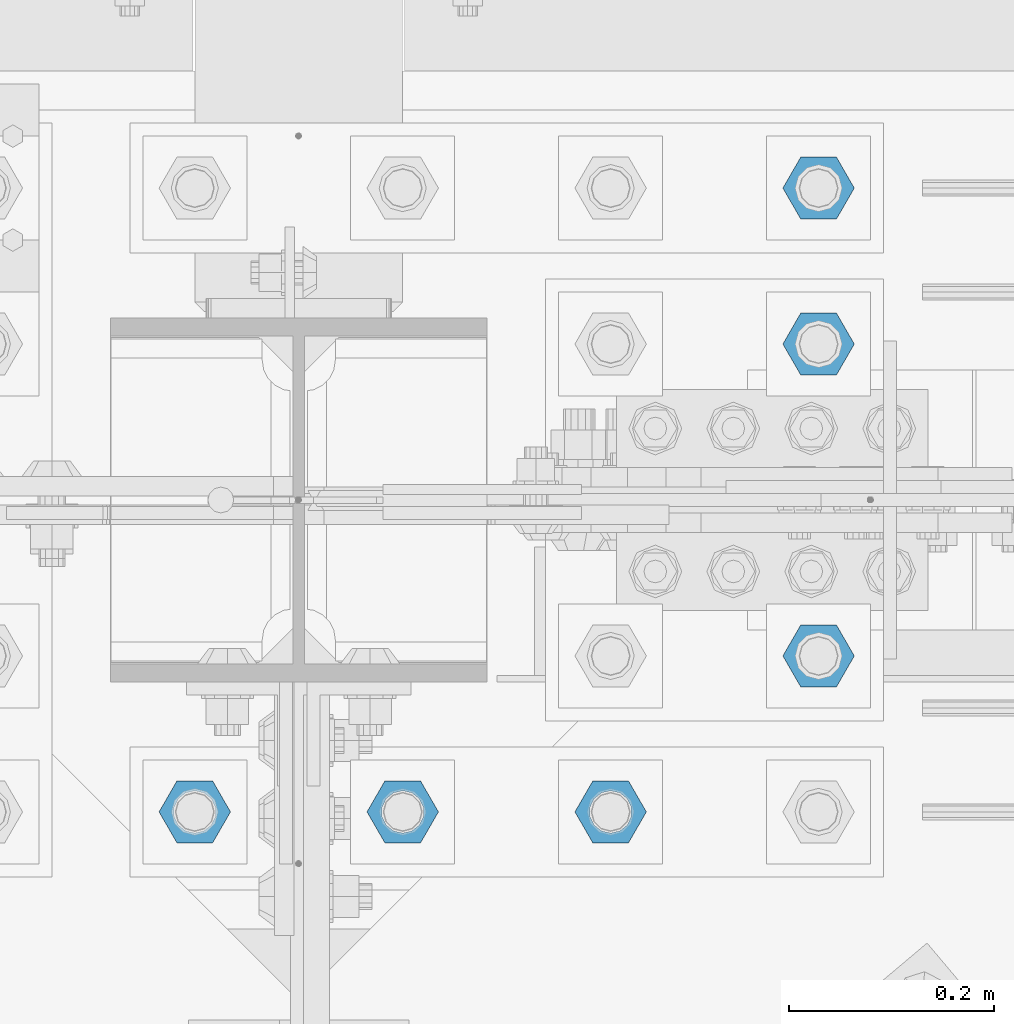
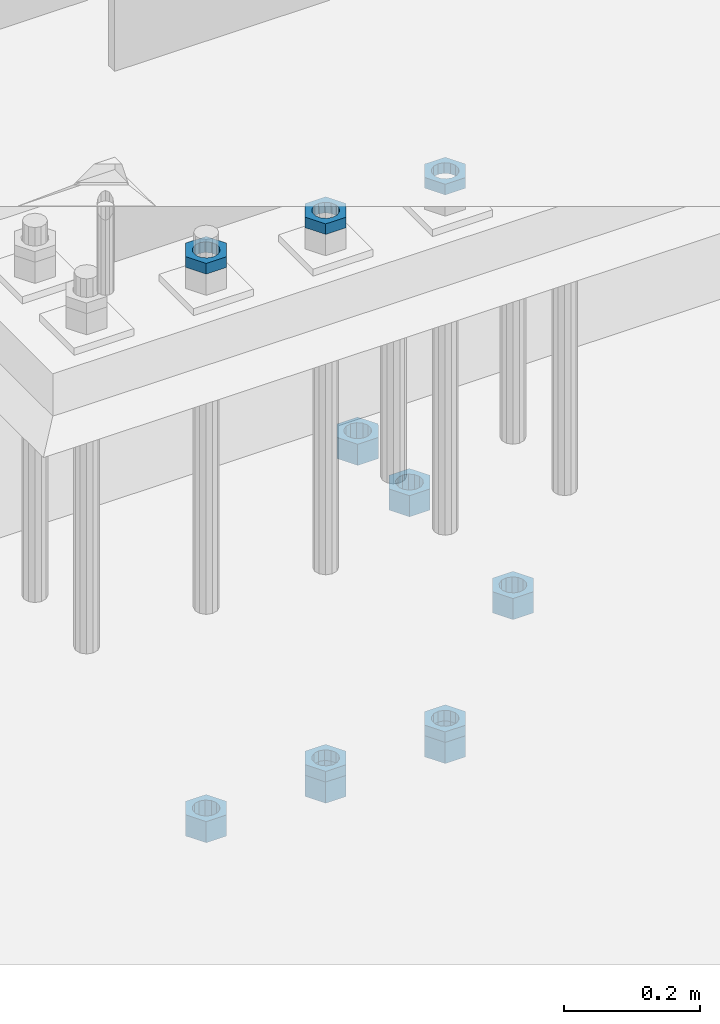
# One storey, part 2881 of 3843: 11 beams, 1 element without a shape of its own.
"""IFC2X3 building model written with IfcOpenShell, lengths in millimetres."""

import ifcopenshell
import ifcopenshell.guid

model = None  # the IFC model being written
_history = None  # IfcOwnerHistory: only IFC2X3 demands one
_inside = {}  # id of a spatial element -> (the spatial element, [elements in it])
_under = {}  # id of a project, library or spatial element -> (it, [spatial elements below it])
_declared = {}  # id of a project -> (the project, [libraries it declares])
_typed = {}  # id of a type object -> (the type object, [elements of that type])
_made_of = {}  # id of a material, layer set ... -> (it, [elements and type objects made of it])


def new_model(schema):
    """Start an empty IFC model of exactly this schema.

    Asked for "IFC4X3", IfcOpenShell would pick the latest addendum, in which some entities
    have other attributes; the version numbers below select the first issue.
    IFC2X3 requires an IfcOwnerHistory on every rooted entity: one is made here for all.
    """
    global model, _history
    if schema == "IFC4X3":
        model = ifcopenshell.file(schema_version=(4, 3, 0, 0))
    else:
        model = ifcopenshell.file(schema=schema)
    _inside.clear()
    _under.clear()
    _declared.clear()
    _typed.clear()
    _made_of.clear()
    _history = None
    if model.schema == "IFC2X3":
        org = make("IfcOrganization", Name="unknown")
        user = make(
            "IfcPersonAndOrganization",
            ThePerson=make("IfcPerson", FamilyName="unknown"),
            TheOrganization=org,
        )
        app = make(
            "IfcApplication",
            ApplicationDeveloper=org,
            Version="unknown",
            ApplicationFullName="unknown",
            ApplicationIdentifier="unknown",
        )
        _history = make(
            "IfcOwnerHistory",
            OwningUser=user,
            OwningApplication=app,
            ChangeAction="ADDED",
            CreationDate=0,
        )
    return model


def make(cls, **values):
    """One entity of the class cls with the attributes given. An attribute that is None is left unset."""
    return model.create_entity(
        cls, **{name: value for name, value in values.items() if value is not None}
    )


def rooted(cls, **values):
    """An entity with a GlobalId (a new one), such as an element, a storey or a relation."""
    return make(cls, GlobalId=ifcopenshell.guid.new(), OwnerHistory=_history, **values)


def si_unit(unit_type, name, prefix=None):
    """IfcSIUnit, for example si_unit("LENGTHUNIT", "METRE", prefix="MILLI")."""
    return make("IfcSIUnit", UnitType=unit_type, Prefix=prefix, Name=name)


def assignment(units):
    """IfcUnitAssignment: the units of a project."""
    return None if units is None else make("IfcUnitAssignment", Units=units)


def point(xyz):
    """IfcCartesianPoint."""
    return None if xyz is None else make("IfcCartesianPoint", Coordinates=xyz)


def direction(xyz):
    """IfcDirection."""
    return None if xyz is None else make("IfcDirection", DirectionRatios=xyz)


def frame(location, z_axis=None, x_axis=None):
    """IfcAxis2Placement3D, a coordinate frame: its origin and axes. An axis left out is left unset."""
    return make(
        "IfcAxis2Placement3D",
        Location=point(location),
        Axis=direction(z_axis),
        RefDirection=direction(x_axis),
    )


def origin_with_axes():
    """The frame at (0, 0, 0) with the z axis (0, 0, 1) and the x axis (1, 0, 0) written out."""
    return frame((0.0, 0.0, 0.0), z_axis=(0.0, 0.0, 1.0), x_axis=(1.0, 0.0, 0.0))


def place(relative_to, where):
    """IfcLocalPlacement: puts the frame where relative to a parent placement (None: the world)."""
    return make(
        "IfcLocalPlacement", PlacementRelTo=relative_to, RelativePlacement=where
    )


def context(
    kind, dimensions, precision=None, world=None, true_north=None, identifier=None
):
    """IfcGeometricRepresentationContext, for example the 3D "Model" context."""
    return make(
        "IfcGeometricRepresentationContext",
        ContextIdentifier=identifier,
        ContextType=kind,
        CoordinateSpaceDimension=dimensions,
        Precision=precision,
        WorldCoordinateSystem=world,
        TrueNorth=true_north,
    )


def subcontext(parent, identifier, kind, view, scale=None):
    """IfcGeometricRepresentationSubContext, for example "Body" below "Model"."""
    return make(
        "IfcGeometricRepresentationSubContext",
        ContextIdentifier=identifier,
        ContextType=kind,
        ParentContext=parent,
        TargetScale=scale,
        TargetView=view,
    )


def project(units=None, contexts=None):
    """IfcProject with its units and contexts."""
    return rooted(
        "IfcProject",
        Name="project",
        RepresentationContexts=contexts,
        UnitsInContext=assignment(units),
    )


def spatial(cls, under=None, at=None, **own):
    """A site, building, storey or space (cls), placed at a placement, below another one or the project."""
    s = rooted(cls, ObjectPlacement=at, **own)
    if under is not None:
        _under.setdefault(under.id(), (under, []))[1].append(s)
    return s


def faces_of(points, faces, orient=None, outer=None):
    """IfcFace entities. A face is a list of loops; a loop is a list of indices into points, from 0.

    orient and outer hold one flag for each loop. By default every Orientation is true, the
    first loop of a face is its IfcFaceOuterBound and the others are IfcFaceBound.
    """
    made = []
    for i, loops in enumerate(faces):
        bounds = []
        for j, loop in enumerate(loops):
            is_outer = j == 0 if outer is None else outer[i][j]
            bounds.append(
                make(
                    "IfcFaceOuterBound" if is_outer else "IfcFaceBound",
                    Bound=make("IfcPolyLoop", Polygon=[points[k] for k in loop]),
                    Orientation=True if orient is None else orient[i][j],
                )
            )
        made.append(make("IfcFace", Bounds=bounds))
    return made


def faceted_brep(points, faces, orient=None, outer=None, voids=None):
    """IfcFacetedBrep: a solid bounded by flat faces; with voids (closed shells), ...WithVoids."""
    shared = [point(p) for p in points]
    hull = make("IfcClosedShell", CfsFaces=faces_of(shared, faces, orient, outer))
    if voids is None:
        return make("IfcFacetedBrep", Outer=hull)
    return make(
        "IfcFacetedBrepWithVoids",
        Outer=hull,
        Voids=[
            make(cls, CfsFaces=faces_of(shared, fs, o, b)) for cls, fs, o, b in voids
        ],
    )


def shape(context_of_items, identifier, shape_type, items):
    """IfcShapeRepresentation: the items that make up one representation, for example the "Body"."""
    return make(
        "IfcShapeRepresentation",
        ContextOfItems=context_of_items,
        RepresentationIdentifier=identifier,
        RepresentationType=shape_type,
        Items=items,
    )


def material(Name=None, Category=None):
    """IfcMaterial."""
    return make("IfcMaterial", Name=Name, Category=Category)


def made_of(thing, what):
    """Note that an element or type object is made of a material, layer set ...; save() writes the relation."""
    if what is not None:
        _made_of.setdefault(what.id(), (what, []))[1].append(thing)
    return thing


def type_object(cls, material=None, **own):
    """A type object (cls), such as IfcWallType, which elements share."""
    return made_of(rooted(cls, **own), material)


def element(
    cls,
    number,
    at=None,
    inside=None,
    cuts=None,
    type_object=None,
    material=None,
    context=None,
    identifier="Body",
    shape_type=None,
    held_by="IfcProductDefinitionShape",
    body=None,
    shapes=None,
    **own,
):
    """One element of the class cls, such as IfcWall. Its Tag is "e" and its number.

    at: its placement. inside: the storey or other place that contains it. cuts: it is an
    opening in that element (IfcRelVoidsElement). A single representation is given by context,
    identifier, shape_type and body (its items); several are given by shapes. held_by: the class
    of the entity that holds the representations. save() writes the other relations.
    """
    e = rooted(cls, Tag="e%d" % number, ObjectPlacement=at, **own)
    if body is not None:
        shapes = [shape(context, identifier, shape_type, body)]
    if shapes is not None:
        e.Representation = make(held_by, Representations=shapes)
    if inside is not None:
        _inside.setdefault(inside.id(), (inside, []))[1].append(e)
    if cuts is not None:
        rooted(
            "IfcRelVoidsElement", RelatingBuildingElement=cuts, RelatedOpeningElement=e
        )
    if type_object is not None:
        _typed.setdefault(type_object.id(), (type_object, []))[1].append(e)
    return made_of(e, material)


def aggregate(whole, parts):
    """IfcRelAggregates: a whole, such as a stair, and the parts it consists of."""
    return rooted("IfcRelAggregates", RelatingObject=whole, RelatedObjects=parts)


def save(model, path):
    """Write the relations noted so far, then the file.

    IfcRelAggregates (storeys below a building ...), IfcRelContainedInSpatialStructure (elements
    in a storey), IfcRelDefinesByType, IfcRelAssociatesMaterial and IfcRelDeclares: one each for
    every whole, place, type object, material and project.
    """
    for whole, parts in _under.values():
        aggregate(whole, parts)
    for where, things in _inside.values():
        rooted(
            "IfcRelContainedInSpatialStructure",
            RelatedElements=things,
            RelatingStructure=where,
        )
    for kind, things in _typed.values():
        rooted("IfcRelDefinesByType", RelatedObjects=things, RelatingType=kind)
    for what, things in _made_of.values():
        rooted("IfcRelAssociatesMaterial", RelatedObjects=things, RelatingMaterial=what)
    for by, libraries in _declared.values():
        rooted("IfcRelDeclares", RelatingContext=by, RelatedDefinitions=libraries)
    model.write(path)


model = new_model("IFC2X3")

# Units and contexts
model_context = context("Model", 3, precision=1e-05, world=origin_with_axes())
body_context = subcontext(model_context, "Body", "Model", "MODEL_VIEW")
ifc_project = project(units=[si_unit("LENGTHUNIT", "METRE", prefix="MILLI"), si_unit("AREAUNIT", "SQUARE_METRE"), si_unit("VOLUMEUNIT", "CUBIC_METRE"), si_unit("MASSUNIT", "GRAM", prefix="KILO"), si_unit("TIMEUNIT", "SECOND"), si_unit("PLANEANGLEUNIT", "RADIAN"), si_unit("SOLIDANGLEUNIT", "STERADIAN"), si_unit("THERMODYNAMICTEMPERATUREUNIT", "DEGREE_CELSIUS"), si_unit("LUMINOUSINTENSITYUNIT", "LUMEN")], contexts=[model_context])

# Site, building, storey
site_placement = place(None, origin_with_axes())
site = spatial("IfcSite", under=ifc_project, at=site_placement, CompositionType="ELEMENT")
building_placement = place(site_placement, origin_with_axes())
building = spatial("IfcBuilding", under=site, at=building_placement, Name="Undefined", CompositionType="ELEMENT")
storey_placement = place(building_placement, origin_with_axes())
storey = spatial("IfcBuildingStorey", under=building, at=storey_placement, Name="Undefined", CompositionType="ELEMENT", Elevation=0.0)

# Assembly, beams
assembly_placement = place(storey_placement, origin_with_axes())
assembly = element("IfcElementAssembly", 1, at=assembly_placement, inside=storey, Name="TEMPLATE", AssemblyPlace="NOTDEFINED", PredefinedType="RIGID_FRAME")
ifc_material = material(Name="STEEL/A572-50")
beam_type_1 = type_object("IfcBeamType", Name="1-1/2_HEAVY_HEX_NUT", PredefinedType="NOTDEFINED")
beam_1_placement = place(assembly_placement, frame((49504.6, 92519.5, 29298.9000015259), z_axis=(0.0, 1.0, 0.0), x_axis=(0.0, 0.0, -1.0)))
beam_1 = element("IfcBeam", 2, at=beam_1_placement, type_object=beam_type_1, material=ifc_material, Name="NUT", ObjectType="1-1/2_HEAVY_HEX_NUT", context=body_context, shape_type="Brep", body=[
    faceted_brep([(0.0, -34.9199981689453, 0.0), (0.0, -17.4599990844727, -30.25), (38.0999999999985, -17.4599990844727, -30.25), (38.0999999999985, -34.9199981689453, 0.0), (0.0, 17.4599990844727, -30.25), (38.0999999999985, 17.4599990844727, -30.25), (0.0, 34.9199981689453, 0.0), (38.0999999999985, 34.9199981689453, 0.0), (0.0, 17.4599990844727, 30.25), (38.0999999999985, 17.4599990844727, 30.25), (0.0, -17.4599990844727, 30.25), (38.0999999999985, -17.4599990844727, 30.25), (0.0, 0.0, 20.6399993896484), (0.0, 8.9553601105581, 18.5959968835959), (38.0999999999985, 8.9553601105581, 18.5959968835959), (38.0999999999985, 0.0, 20.6399993896484), (0.0, 16.1370013209525, 12.8688291298167), (38.0999999999985, 16.1370013209525, 12.8688291298167), (0.0, 20.1225115123816, 4.59283194104501), (38.0999999999985, 20.1225115123816, 4.59283194104501), (0.0, 20.1225115123816, -4.59283194104501), (38.0999999999985, 20.1225115123816, -4.59283194104501), (0.0, 16.1370013209525, -12.8688291298167), (38.0999999999985, 16.1370013209525, -12.8688291298167), (0.0, 8.9553601105581, -18.5959968835959), (38.0999999999985, 8.9553601105581, -18.5959968835959), (0.0, 0.0, -20.6399993896484), (38.0999999999985, 0.0, -20.6399993896484), (0.0, -8.9553601105581, -18.5959968835959), (38.0999999999985, -8.9553601105581, -18.5959968835959), (0.0, -16.1370013209525, -12.8688291298167), (38.0999999999985, -16.1370013209525, -12.8688291298167), (0.0, -20.1225115123816, -4.59283194104501), (38.0999999999985, -20.1225115123816, -4.59283194104501), (0.0, -20.1225115123816, 4.59283194104501), (38.0999999999985, -20.1225115123816, 4.59283194104501), (0.0, -16.1370013209525, 12.8688291298167), (38.0999999999985, -16.1370013209525, 12.8688291298167), (0.0, -8.9553601105581, 18.5959968835959), (38.0999999999985, -8.9553601105581, 18.5959968835959)], [[[0, 1, 2, 3]], [[1, 4, 5, 2]], [[4, 6, 7, 5]], [[6, 8, 9, 7]], [[8, 10, 11, 9]], [[10, 0, 3, 11]], [[12, 13, 14, 15]], [[13, 16, 17, 14]], [[16, 18, 19, 17]], [[18, 20, 21, 19]], [[20, 22, 23, 21]], [[22, 24, 25, 23]], [[24, 26, 27, 25]], [[26, 28, 29, 27]], [[28, 30, 31, 29]], [[30, 32, 33, 31]], [[32, 34, 35, 33]], [[34, 36, 37, 35]], [[36, 38, 39, 37]], [[38, 12, 15, 39]], [[5, 7, 9, 11, 3, 2], [17, 19, 21, 23, 25, 27, 29, 31, 33, 35, 37, 39, 15, 14]], [[10, 8, 6, 4, 1, 0], [38, 36, 34, 32, 30, 28, 26, 24, 22, 20, 18, 16, 13, 12]]]),
])
beam_2_placement = place(assembly_placement, frame((49504.6, 92367.1, 29298.9000015259), z_axis=(0.0, 1.0, 0.0), x_axis=(0.0, 0.0, -1.0)))
beam_2 = element("IfcBeam", 3, at=beam_2_placement, type_object=beam_type_1, material=ifc_material, Name="NUT", ObjectType="1-1/2_HEAVY_HEX_NUT", context=body_context, shape_type="Brep", body=[
    faceted_brep([(0.0, -34.9199981689453, 0.0), (0.0, -17.4599990844727, -30.25), (38.0999999999985, -17.4599990844727, -30.25), (38.0999999999985, -34.9199981689453, 0.0), (0.0, 17.4599990844727, -30.25), (38.0999999999985, 17.4599990844727, -30.25), (0.0, 34.9199981689453, 0.0), (38.0999999999985, 34.9199981689453, 0.0), (0.0, 17.4599990844727, 30.25), (38.0999999999985, 17.4599990844727, 30.25), (0.0, -17.4599990844727, 30.25), (38.0999999999985, -17.4599990844727, 30.25), (0.0, 0.0, 20.6399993896484), (0.0, 8.9553601105581, 18.5959968835959), (38.0999999999985, 8.9553601105581, 18.5959968835959), (38.0999999999985, 0.0, 20.6399993896484), (0.0, 16.1370013209525, 12.8688291298167), (38.0999999999985, 16.1370013209525, 12.8688291298167), (0.0, 20.1225115123816, 4.59283194104501), (38.0999999999985, 20.1225115123816, 4.59283194104501), (0.0, 20.1225115123816, -4.59283194104501), (38.0999999999985, 20.1225115123816, -4.59283194104501), (0.0, 16.1370013209525, -12.8688291298167), (38.0999999999985, 16.1370013209525, -12.8688291298167), (0.0, 8.9553601105581, -18.5959968835959), (38.0999999999985, 8.9553601105581, -18.5959968835959), (0.0, 0.0, -20.6399993896484), (38.0999999999985, 0.0, -20.6399993896484), (0.0, -8.9553601105581, -18.5959968835959), (38.0999999999985, -8.9553601105581, -18.5959968835959), (0.0, -16.1370013209525, -12.8688291298167), (38.0999999999985, -16.1370013209525, -12.8688291298167), (0.0, -20.1225115123816, -4.59283194104501), (38.0999999999985, -20.1225115123816, -4.59283194104501), (0.0, -20.1225115123816, 4.59283194104501), (38.0999999999985, -20.1225115123816, 4.59283194104501), (0.0, -16.1370013209525, 12.8688291298167), (38.0999999999985, -16.1370013209525, 12.8688291298167), (0.0, -8.9553601105581, 18.5959968835959), (38.0999999999985, -8.9553601105581, 18.5959968835959)], [[[0, 1, 2, 3]], [[1, 4, 5, 2]], [[4, 6, 7, 5]], [[6, 8, 9, 7]], [[8, 10, 11, 9]], [[10, 0, 3, 11]], [[12, 13, 14, 15]], [[13, 16, 17, 14]], [[16, 18, 19, 17]], [[18, 20, 21, 19]], [[20, 22, 23, 21]], [[22, 24, 25, 23]], [[24, 26, 27, 25]], [[26, 28, 29, 27]], [[28, 30, 31, 29]], [[30, 32, 33, 31]], [[32, 34, 35, 33]], [[34, 36, 37, 35]], [[36, 38, 39, 37]], [[38, 12, 15, 39]], [[5, 7, 9, 11, 3, 2], [17, 19, 21, 23, 25, 27, 29, 31, 33, 35, 37, 39, 15, 14]], [[10, 8, 6, 4, 1, 0], [38, 36, 34, 32, 30, 28, 26, 24, 22, 20, 18, 16, 13, 12]]]),
])
beam_3_placement = place(assembly_placement, frame((49504.6, 92062.3, 29298.9000015259), z_axis=(0.0, 1.0, 0.0), x_axis=(0.0, 0.0, -1.0)))
beam_3 = element("IfcBeam", 4, at=beam_3_placement, type_object=beam_type_1, material=ifc_material, Name="NUT", ObjectType="1-1/2_HEAVY_HEX_NUT", context=body_context, shape_type="Brep", body=[
    faceted_brep([(0.0, -34.9199981689453, 0.0), (0.0, -17.4599990844727, -30.25), (38.0999999999985, -17.4599990844727, -30.25), (38.0999999999985, -34.9199981689453, 0.0), (0.0, 17.4599990844727, -30.25), (38.0999999999985, 17.4599990844727, -30.25), (0.0, 34.9199981689453, 0.0), (38.0999999999985, 34.9199981689453, 0.0), (0.0, 17.4599990844727, 30.25), (38.0999999999985, 17.4599990844727, 30.25), (0.0, -17.4599990844727, 30.25), (38.0999999999985, -17.4599990844727, 30.25), (0.0, 0.0, 20.6399993896484), (0.0, 8.9553601105581, 18.5959968835959), (38.0999999999985, 8.9553601105581, 18.5959968835959), (38.0999999999985, 0.0, 20.6399993896484), (0.0, 16.1370013209525, 12.8688291298167), (38.0999999999985, 16.1370013209525, 12.8688291298167), (0.0, 20.1225115123816, 4.59283194104501), (38.0999999999985, 20.1225115123816, 4.59283194104501), (0.0, 20.1225115123816, -4.59283194104501), (38.0999999999985, 20.1225115123816, -4.59283194104501), (0.0, 16.1370013209525, -12.8688291298167), (38.0999999999985, 16.1370013209525, -12.8688291298167), (0.0, 8.9553601105581, -18.5959968835959), (38.0999999999985, 8.9553601105581, -18.5959968835959), (0.0, 0.0, -20.6399993896484), (38.0999999999985, 0.0, -20.6399993896484), (0.0, -8.9553601105581, -18.5959968835959), (38.0999999999985, -8.9553601105581, -18.5959968835959), (0.0, -16.1370013209525, -12.8688291298167), (38.0999999999985, -16.1370013209525, -12.8688291298167), (0.0, -20.1225115123816, -4.59283194104501), (38.0999999999985, -20.1225115123816, -4.59283194104501), (0.0, -20.1225115123816, 4.59283194104501), (38.0999999999985, -20.1225115123816, 4.59283194104501), (0.0, -16.1370013209525, 12.8688291298167), (38.0999999999985, -16.1370013209525, 12.8688291298167), (0.0, -8.9553601105581, 18.5959968835959), (38.0999999999985, -8.9553601105581, 18.5959968835959)], [[[0, 1, 2, 3]], [[1, 4, 5, 2]], [[4, 6, 7, 5]], [[6, 8, 9, 7]], [[8, 10, 11, 9]], [[10, 0, 3, 11]], [[12, 13, 14, 15]], [[13, 16, 17, 14]], [[16, 18, 19, 17]], [[18, 20, 21, 19]], [[20, 22, 23, 21]], [[22, 24, 25, 23]], [[24, 26, 27, 25]], [[26, 28, 29, 27]], [[28, 30, 31, 29]], [[30, 32, 33, 31]], [[32, 34, 35, 33]], [[34, 36, 37, 35]], [[36, 38, 39, 37]], [[38, 12, 15, 39]], [[5, 7, 9, 11, 3, 2], [17, 19, 21, 23, 25, 27, 29, 31, 33, 35, 37, 39, 15, 14]], [[10, 8, 6, 4, 1, 0], [38, 36, 34, 32, 30, 28, 26, 24, 22, 20, 18, 16, 13, 12]]]),
])
beam_4_placement = place(assembly_placement, frame((48895.0, 91909.9, 29203.6500015259), z_axis=(0.0, -1.0, 0.0), x_axis=(0.0, 0.0, -1.0)))
beam_4 = element("IfcBeam", 5, at=beam_4_placement, type_object=beam_type_1, material=ifc_material, Name="NUT", ObjectType="1-1/2_HEAVY_HEX_NUT", context=body_context, shape_type="Brep", body=[
    faceted_brep([(0.0, -34.9199981689453, 0.0), (0.0, -17.4599990844727, -30.25), (38.0999999999985, -17.4599990844727, -30.25), (38.0999999999985, -34.9199981689453, 0.0), (0.0, 17.4599990844727, -30.25), (38.0999999999985, 17.4599990844727, -30.25), (0.0, 34.9199981689453, 0.0), (38.0999999999985, 34.9199981689453, 0.0), (0.0, 17.4599990844727, 30.25), (38.0999999999985, 17.4599990844727, 30.25), (0.0, -17.4599990844727, 30.25), (38.0999999999985, -17.4599990844727, 30.25), (0.0, 0.0, 20.6399993896484), (0.0, 8.9553601105581, 18.5959968835959), (38.0999999999985, 8.9553601105581, 18.5959968835959), (38.0999999999985, 0.0, 20.6399993896484), (0.0, 16.1370013209525, 12.8688291298167), (38.0999999999985, 16.1370013209525, 12.8688291298167), (0.0, 20.1225115123816, 4.59283194104501), (38.0999999999985, 20.1225115123816, 4.59283194104501), (0.0, 20.1225115123816, -4.59283194104501), (38.0999999999985, 20.1225115123816, -4.59283194104501), (0.0, 16.1370013209525, -12.8688291298167), (38.0999999999985, 16.1370013209525, -12.8688291298167), (0.0, 8.9553601105581, -18.5959968835959), (38.0999999999985, 8.9553601105581, -18.5959968835959), (0.0, 0.0, -20.6399993896484), (38.0999999999985, 0.0, -20.6399993896484), (0.0, -8.9553601105581, -18.5959968835959), (38.0999999999985, -8.9553601105581, -18.5959968835959), (0.0, -16.1370013209525, -12.8688291298167), (38.0999999999985, -16.1370013209525, -12.8688291298167), (0.0, -20.1225115123816, -4.59283194104501), (38.0999999999985, -20.1225115123816, -4.59283194104501), (0.0, -20.1225115123816, 4.59283194104501), (38.0999999999985, -20.1225115123816, 4.59283194104501), (0.0, -16.1370013209525, 12.8688291298167), (38.0999999999985, -16.1370013209525, 12.8688291298167), (0.0, -8.9553601105581, 18.5959968835959), (38.0999999999985, -8.9553601105581, 18.5959968835959)], [[[0, 1, 2, 3]], [[1, 4, 5, 2]], [[4, 6, 7, 5]], [[6, 8, 9, 7]], [[8, 10, 11, 9]], [[10, 0, 3, 11]], [[12, 13, 14, 15]], [[13, 16, 17, 14]], [[16, 18, 19, 17]], [[18, 20, 21, 19]], [[20, 22, 23, 21]], [[22, 24, 25, 23]], [[24, 26, 27, 25]], [[26, 28, 29, 27]], [[28, 30, 31, 29]], [[30, 32, 33, 31]], [[32, 34, 35, 33]], [[34, 36, 37, 35]], [[36, 38, 39, 37]], [[38, 12, 15, 39]], [[5, 7, 9, 11, 3, 2], [17, 19, 21, 23, 25, 27, 29, 31, 33, 35, 37, 39, 15, 14]], [[10, 8, 6, 4, 1, 0], [38, 36, 34, 32, 30, 28, 26, 24, 22, 20, 18, 16, 13, 12]]]),
])
beam_5_placement = place(assembly_placement, frame((49098.2, 91909.9, 29203.6500015259), z_axis=(0.0, -1.0, 0.0), x_axis=(0.0, 0.0, -1.0)))
beam_5 = element("IfcBeam", 6, at=beam_5_placement, type_object=beam_type_1, material=ifc_material, Name="NUT", ObjectType="1-1/2_HEAVY_HEX_NUT", context=body_context, shape_type="Brep", body=[
    faceted_brep([(0.0, -34.9199981689453, 0.0), (0.0, -17.4599990844727, -30.25), (38.0999999999985, -17.4599990844727, -30.25), (38.0999999999985, -34.9199981689453, 0.0), (0.0, 17.4599990844727, -30.25), (38.0999999999985, 17.4599990844727, -30.25), (0.0, 34.9199981689453, 0.0), (38.0999999999985, 34.9199981689453, 0.0), (0.0, 17.4599990844727, 30.25), (38.0999999999985, 17.4599990844727, 30.25), (0.0, -17.4599990844727, 30.25), (38.0999999999985, -17.4599990844727, 30.25), (0.0, 0.0, 20.6399993896484), (0.0, 8.9553601105581, 18.5959968835959), (38.0999999999985, 8.9553601105581, 18.5959968835959), (38.0999999999985, 0.0, 20.6399993896484), (0.0, 16.1370013209525, 12.8688291298167), (38.0999999999985, 16.1370013209525, 12.8688291298167), (0.0, 20.1225115123816, 4.59283194104501), (38.0999999999985, 20.1225115123816, 4.59283194104501), (0.0, 20.1225115123816, -4.59283194104501), (38.0999999999985, 20.1225115123816, -4.59283194104501), (0.0, 16.1370013209525, -12.8688291298167), (38.0999999999985, 16.1370013209525, -12.8688291298167), (0.0, 8.9553601105581, -18.5959968835959), (38.0999999999985, 8.9553601105581, -18.5959968835959), (0.0, 0.0, -20.6399993896484), (38.0999999999985, 0.0, -20.6399993896484), (0.0, -8.9553601105581, -18.5959968835959), (38.0999999999985, -8.9553601105581, -18.5959968835959), (0.0, -16.1370013209525, -12.8688291298167), (38.0999999999985, -16.1370013209525, -12.8688291298167), (0.0, -20.1225115123816, -4.59283194104501), (38.0999999999985, -20.1225115123816, -4.59283194104501), (0.0, -20.1225115123816, 4.59283194104501), (38.0999999999985, -20.1225115123816, 4.59283194104501), (0.0, -16.1370013209525, 12.8688291298167), (38.0999999999985, -16.1370013209525, 12.8688291298167), (0.0, -8.9553601105581, 18.5959968835959), (38.0999999999985, -8.9553601105581, 18.5959968835959)], [[[0, 1, 2, 3]], [[1, 4, 5, 2]], [[4, 6, 7, 5]], [[6, 8, 9, 7]], [[8, 10, 11, 9]], [[10, 0, 3, 11]], [[12, 13, 14, 15]], [[13, 16, 17, 14]], [[16, 18, 19, 17]], [[18, 20, 21, 19]], [[20, 22, 23, 21]], [[22, 24, 25, 23]], [[24, 26, 27, 25]], [[26, 28, 29, 27]], [[28, 30, 31, 29]], [[30, 32, 33, 31]], [[32, 34, 35, 33]], [[34, 36, 37, 35]], [[36, 38, 39, 37]], [[38, 12, 15, 39]], [[5, 7, 9, 11, 3, 2], [17, 19, 21, 23, 25, 27, 29, 31, 33, 35, 37, 39, 15, 14]], [[10, 8, 6, 4, 1, 0], [38, 36, 34, 32, 30, 28, 26, 24, 22, 20, 18, 16, 13, 12]]]),
])
beam_6_placement = place(assembly_placement, frame((49301.4, 91909.9, 29203.6500015259), z_axis=(0.0, 1.0, 0.0), x_axis=(0.0, 0.0, -1.0)))
beam_6 = element("IfcBeam", 7, at=beam_6_placement, type_object=beam_type_1, material=ifc_material, Name="NUT", ObjectType="1-1/2_HEAVY_HEX_NUT", context=body_context, shape_type="Brep", body=[
    faceted_brep([(0.0, -34.9199981689453, 0.0), (0.0, -17.4599990844727, -30.25), (38.0999999999985, -17.4599990844727, -30.25), (38.0999999999985, -34.9199981689453, 0.0), (0.0, 17.4599990844727, -30.25), (38.0999999999985, 17.4599990844727, -30.25), (0.0, 34.9199981689453, 0.0), (38.0999999999985, 34.9199981689453, 0.0), (0.0, 17.4599990844727, 30.25), (38.0999999999985, 17.4599990844727, 30.25), (0.0, -17.4599990844727, 30.25), (38.0999999999985, -17.4599990844727, 30.25), (0.0, 0.0, 20.6399993896484), (0.0, 8.9553601105581, 18.5959968835959), (38.0999999999985, 8.9553601105581, 18.5959968835959), (38.0999999999985, 0.0, 20.6399993896484), (0.0, 16.1370013209525, 12.8688291298167), (38.0999999999985, 16.1370013209525, 12.8688291298167), (0.0, 20.1225115123816, 4.59283194104501), (38.0999999999985, 20.1225115123816, 4.59283194104501), (0.0, 20.1225115123816, -4.59283194104501), (38.0999999999985, 20.1225115123816, -4.59283194104501), (0.0, 16.1370013209525, -12.8688291298167), (38.0999999999985, 16.1370013209525, -12.8688291298167), (0.0, 8.9553601105581, -18.5959968835959), (38.0999999999985, 8.9553601105581, -18.5959968835959), (0.0, 0.0, -20.6399993896484), (38.0999999999985, 0.0, -20.6399993896484), (0.0, -8.9553601105581, -18.5959968835959), (38.0999999999985, -8.9553601105581, -18.5959968835959), (0.0, -16.1370013209525, -12.8688291298167), (38.0999999999985, -16.1370013209525, -12.8688291298167), (0.0, -20.1225115123816, -4.59283194104501), (38.0999999999985, -20.1225115123816, -4.59283194104501), (0.0, -20.1225115123816, 4.59283194104501), (38.0999999999985, -20.1225115123816, 4.59283194104501), (0.0, -16.1370013209525, 12.8688291298167), (38.0999999999985, -16.1370013209525, 12.8688291298167), (0.0, -8.9553601105581, 18.5959968835959), (38.0999999999985, -8.9553601105581, 18.5959968835959)], [[[0, 1, 2, 3]], [[1, 4, 5, 2]], [[4, 6, 7, 5]], [[6, 8, 9, 7]], [[8, 10, 11, 9]], [[10, 0, 3, 11]], [[12, 13, 14, 15]], [[13, 16, 17, 14]], [[16, 18, 19, 17]], [[18, 20, 21, 19]], [[20, 22, 23, 21]], [[22, 24, 25, 23]], [[24, 26, 27, 25]], [[26, 28, 29, 27]], [[28, 30, 31, 29]], [[30, 32, 33, 31]], [[32, 34, 35, 33]], [[34, 36, 37, 35]], [[36, 38, 39, 37]], [[38, 12, 15, 39]], [[5, 7, 9, 11, 3, 2], [17, 19, 21, 23, 25, 27, 29, 31, 33, 35, 37, 39, 15, 14]], [[10, 8, 6, 4, 1, 0], [38, 36, 34, 32, 30, 28, 26, 24, 22, 20, 18, 16, 13, 12]]]),
])
beam_type_2 = type_object("IfcBeamType", Name="1-1/2_HALF_NUT", PredefinedType="NOTDEFINED")
beam_7_placement = place(assembly_placement, frame((48895.0, 91909.9, 30206.95), z_axis=(0.0, -1.0, 0.0), x_axis=(0.0, 0.0, -1.0)))
beam_7 = element("IfcBeam", 8, at=beam_7_placement, type_object=beam_type_2, material=ifc_material, Name="NUT", ObjectType="1-1/2_HALF_NUT", context=body_context, shape_type="Brep", body=[
    faceted_brep([(0.0, -34.9199981689453, 0.0), (0.0, -17.4599990844727, -30.25), (19.0500000000029, -17.4599990844727, -30.25), (19.0500000000029, -34.9199981689453, 0.0), (0.0, 17.4599990844727, -30.25), (19.0500000000029, 17.4599990844727, -30.25), (0.0, 34.9199981689453, 0.0), (19.0500000000029, 34.9199981689453, 0.0), (0.0, 17.4599990844727, 30.25), (19.0500000000029, 17.4599990844727, 30.25), (0.0, -17.4599990844727, 30.25), (19.0500000000029, -17.4599990844727, 30.25), (0.0, 0.0, 20.6399993896484), (0.0, 8.9553601105581, 18.5959968835959), (19.0500000000029, 8.95536011056538, 18.5959968835959), (19.0500000000029, 0.0, 20.6399993896484), (0.0, 16.1370013209525, 12.8688291298167), (19.0500000000029, 16.1370013209489, 12.8688291298167), (0.0, 20.1225115123816, 4.59283194104501), (19.0500000000029, 20.1225115123852, 4.59283194104501), (0.0, 20.1225115123816, -4.59283194104501), (19.0500000000029, 20.1225115123852, -4.59283194104501), (0.0, 16.1370013209525, -12.8688291298167), (19.0500000000029, 16.1370013209489, -12.8688291298167), (0.0, 8.9553601105581, -18.5959968835959), (19.0500000000029, 8.95536011056538, -18.5959968835959), (0.0, 0.0, -20.6399993896484), (19.0500000000029, 0.0, -20.6399993896484), (0.0, -8.9553601105581, -18.5959968835959), (19.0500000000029, -8.95536011056538, -18.5959968835959), (0.0, -16.1370013209525, -12.8688291298167), (19.0500000000029, -16.1370013209489, -12.8688291298167), (0.0, -20.1225115123816, -4.59283194104501), (19.0500000000029, -20.1225115123852, -4.59283194104501), (0.0, -20.1225115123816, 4.59283194104501), (19.0500000000029, -20.1225115123852, 4.59283194104501), (0.0, -16.1370013209525, 12.8688291298167), (19.0500000000029, -16.1370013209489, 12.8688291298167), (0.0, -8.9553601105581, 18.5959968835959), (19.0500000000029, -8.95536011056538, 18.5959968835959)], [[[0, 1, 2, 3]], [[1, 4, 5, 2]], [[4, 6, 7, 5]], [[6, 8, 9, 7]], [[8, 10, 11, 9]], [[10, 0, 3, 11]], [[12, 13, 14, 15]], [[13, 16, 17, 14]], [[16, 18, 19, 17]], [[18, 20, 21, 19]], [[20, 22, 23, 21]], [[22, 24, 25, 23]], [[24, 26, 27, 25]], [[26, 28, 29, 27]], [[28, 30, 31, 29]], [[30, 32, 33, 31]], [[32, 34, 35, 33]], [[34, 36, 37, 35]], [[36, 38, 39, 37]], [[38, 12, 15, 39]], [[5, 7, 9, 11, 3, 2], [17, 19, 21, 23, 25, 27, 29, 31, 33, 35, 37, 39, 15, 14]], [[10, 8, 6, 4, 1, 0], [38, 36, 34, 32, 30, 28, 26, 24, 22, 20, 18, 16, 13, 12]]]),
])
beam_8_placement = place(assembly_placement, frame((49098.2, 91909.9, 29222.7000015259), z_axis=(0.0, -1.0, 0.0), x_axis=(0.0, 0.0, -1.0)))
beam_8 = element("IfcBeam", 9, at=beam_8_placement, type_object=beam_type_2, material=ifc_material, Name="NUT", ObjectType="1-1/2_HALF_NUT", context=body_context, shape_type="Brep", body=[
    faceted_brep([(0.0, -34.9199981689453, 0.0), (0.0, -17.4599990844727, -30.25), (19.0500000000029, -17.4599990844727, -30.25), (19.0500000000029, -34.9199981689453, 0.0), (0.0, 17.4599990844727, -30.25), (19.0500000000029, 17.4599990844727, -30.25), (0.0, 34.9199981689453, 0.0), (19.0500000000029, 34.9199981689453, 0.0), (0.0, 17.4599990844727, 30.25), (19.0500000000029, 17.4599990844727, 30.25), (0.0, -17.4599990844727, 30.25), (19.0500000000029, -17.4599990844727, 30.25), (0.0, 0.0, 20.6399993896484), (0.0, 8.9553601105581, 18.5959968835959), (19.0500000000029, 8.95536011056538, 18.5959968835959), (19.0500000000029, 0.0, 20.6399993896484), (0.0, 16.1370013209525, 12.8688291298167), (19.0500000000029, 16.1370013209489, 12.8688291298167), (0.0, 20.1225115123816, 4.59283194104501), (19.0500000000029, 20.1225115123852, 4.59283194104501), (0.0, 20.1225115123816, -4.59283194104501), (19.0500000000029, 20.1225115123852, -4.59283194104501), (0.0, 16.1370013209525, -12.8688291298167), (19.0500000000029, 16.1370013209489, -12.8688291298167), (0.0, 8.9553601105581, -18.5959968835959), (19.0500000000029, 8.95536011056538, -18.5959968835959), (0.0, 0.0, -20.6399993896484), (19.0500000000029, 0.0, -20.6399993896484), (0.0, -8.9553601105581, -18.5959968835959), (19.0500000000029, -8.95536011056538, -18.5959968835959), (0.0, -16.1370013209525, -12.8688291298167), (19.0500000000029, -16.1370013209489, -12.8688291298167), (0.0, -20.1225115123816, -4.59283194104501), (19.0500000000029, -20.1225115123852, -4.59283194104501), (0.0, -20.1225115123816, 4.59283194104501), (19.0500000000029, -20.1225115123852, 4.59283194104501), (0.0, -16.1370013209525, 12.8688291298167), (19.0500000000029, -16.1370013209489, 12.8688291298167), (0.0, -8.9553601105581, 18.5959968835959), (19.0500000000029, -8.95536011056538, 18.5959968835959)], [[[0, 1, 2, 3]], [[1, 4, 5, 2]], [[4, 6, 7, 5]], [[6, 8, 9, 7]], [[8, 10, 11, 9]], [[10, 0, 3, 11]], [[12, 13, 14, 15]], [[13, 16, 17, 14]], [[16, 18, 19, 17]], [[18, 20, 21, 19]], [[20, 22, 23, 21]], [[22, 24, 25, 23]], [[24, 26, 27, 25]], [[26, 28, 29, 27]], [[28, 30, 31, 29]], [[30, 32, 33, 31]], [[32, 34, 35, 33]], [[34, 36, 37, 35]], [[36, 38, 39, 37]], [[38, 12, 15, 39]], [[5, 7, 9, 11, 3, 2], [17, 19, 21, 23, 25, 27, 29, 31, 33, 35, 37, 39, 15, 14]], [[10, 8, 6, 4, 1, 0], [38, 36, 34, 32, 30, 28, 26, 24, 22, 20, 18, 16, 13, 12]]]),
])
beam_9_placement = place(assembly_placement, frame((49098.2, 91909.9, 30206.95), z_axis=(0.0, -1.0, 0.0), x_axis=(0.0, 0.0, -1.0)))
beam_9 = element("IfcBeam", 10, at=beam_9_placement, type_object=beam_type_2, material=ifc_material, Name="NUT", ObjectType="1-1/2_HALF_NUT", context=body_context, shape_type="Brep", body=[
    faceted_brep([(0.0, -34.9199981689453, 0.0), (0.0, -17.4599990844727, -30.25), (19.0500000000029, -17.4599990844727, -30.25), (19.0500000000029, -34.9199981689453, 0.0), (0.0, 17.4599990844727, -30.25), (19.0500000000029, 17.4599990844727, -30.25), (0.0, 34.9199981689453, 0.0), (19.0500000000029, 34.9199981689453, 0.0), (0.0, 17.4599990844727, 30.25), (19.0500000000029, 17.4599990844727, 30.25), (0.0, -17.4599990844727, 30.25), (19.0500000000029, -17.4599990844727, 30.25), (0.0, 0.0, 20.6399993896484), (0.0, 8.9553601105581, 18.5959968835959), (19.0500000000029, 8.95536011056538, 18.5959968835959), (19.0500000000029, 0.0, 20.6399993896484), (0.0, 16.1370013209525, 12.8688291298167), (19.0500000000029, 16.1370013209489, 12.8688291298167), (0.0, 20.1225115123816, 4.59283194104501), (19.0500000000029, 20.1225115123852, 4.59283194104501), (0.0, 20.1225115123816, -4.59283194104501), (19.0500000000029, 20.1225115123852, -4.59283194104501), (0.0, 16.1370013209525, -12.8688291298167), (19.0500000000029, 16.1370013209489, -12.8688291298167), (0.0, 8.9553601105581, -18.5959968835959), (19.0500000000029, 8.95536011056538, -18.5959968835959), (0.0, 0.0, -20.6399993896484), (19.0500000000029, 0.0, -20.6399993896484), (0.0, -8.9553601105581, -18.5959968835959), (19.0500000000029, -8.95536011056538, -18.5959968835959), (0.0, -16.1370013209525, -12.8688291298167), (19.0500000000029, -16.1370013209489, -12.8688291298167), (0.0, -20.1225115123816, -4.59283194104501), (19.0500000000029, -20.1225115123852, -4.59283194104501), (0.0, -20.1225115123816, 4.59283194104501), (19.0500000000029, -20.1225115123852, 4.59283194104501), (0.0, -16.1370013209525, 12.8688291298167), (19.0500000000029, -16.1370013209489, 12.8688291298167), (0.0, -8.9553601105581, 18.5959968835959), (19.0500000000029, -8.95536011056538, 18.5959968835959)], [[[0, 1, 2, 3]], [[1, 4, 5, 2]], [[4, 6, 7, 5]], [[6, 8, 9, 7]], [[8, 10, 11, 9]], [[10, 0, 3, 11]], [[12, 13, 14, 15]], [[13, 16, 17, 14]], [[16, 18, 19, 17]], [[18, 20, 21, 19]], [[20, 22, 23, 21]], [[22, 24, 25, 23]], [[24, 26, 27, 25]], [[26, 28, 29, 27]], [[28, 30, 31, 29]], [[30, 32, 33, 31]], [[32, 34, 35, 33]], [[34, 36, 37, 35]], [[36, 38, 39, 37]], [[38, 12, 15, 39]], [[5, 7, 9, 11, 3, 2], [17, 19, 21, 23, 25, 27, 29, 31, 33, 35, 37, 39, 15, 14]], [[10, 8, 6, 4, 1, 0], [38, 36, 34, 32, 30, 28, 26, 24, 22, 20, 18, 16, 13, 12]]]),
])
beam_10_placement = place(assembly_placement, frame((49301.4, 91909.9, 29222.7000015259), z_axis=(0.0, 1.0, 0.0), x_axis=(0.0, 0.0, -1.0)))
beam_10 = element("IfcBeam", 11, at=beam_10_placement, type_object=beam_type_2, material=ifc_material, Name="NUT", ObjectType="1-1/2_HALF_NUT", context=body_context, shape_type="Brep", body=[
    faceted_brep([(0.0, -34.9199981689453, 0.0), (0.0, -17.4599990844727, -30.25), (19.0500000000029, -17.4599990844727, -30.25), (19.0500000000029, -34.9199981689453, 0.0), (0.0, 17.4599990844727, -30.25), (19.0500000000029, 17.4599990844727, -30.25), (0.0, 34.9199981689453, 0.0), (19.0500000000029, 34.9199981689453, 0.0), (0.0, 17.4599990844727, 30.25), (19.0500000000029, 17.4599990844727, 30.25), (0.0, -17.4599990844727, 30.25), (19.0500000000029, -17.4599990844727, 30.25), (0.0, 0.0, 20.6399993896484), (0.0, 8.9553601105581, 18.5959968835959), (19.0500000000029, 8.95536011056538, 18.5959968835959), (19.0500000000029, 0.0, 20.6399993896484), (0.0, 16.1370013209525, 12.8688291298167), (19.0500000000029, 16.1370013209489, 12.8688291298167), (0.0, 20.1225115123816, 4.59283194104501), (19.0500000000029, 20.1225115123852, 4.59283194104501), (0.0, 20.1225115123816, -4.59283194104501), (19.0500000000029, 20.1225115123852, -4.59283194104501), (0.0, 16.1370013209525, -12.8688291298167), (19.0500000000029, 16.1370013209489, -12.8688291298167), (0.0, 8.9553601105581, -18.5959968835959), (19.0500000000029, 8.95536011056538, -18.5959968835959), (0.0, 0.0, -20.6399993896484), (19.0500000000029, 0.0, -20.6399993896484), (0.0, -8.9553601105581, -18.5959968835959), (19.0500000000029, -8.95536011056538, -18.5959968835959), (0.0, -16.1370013209525, -12.8688291298167), (19.0500000000029, -16.1370013209489, -12.8688291298167), (0.0, -20.1225115123816, -4.59283194104501), (19.0500000000029, -20.1225115123852, -4.59283194104501), (0.0, -20.1225115123816, 4.59283194104501), (19.0500000000029, -20.1225115123852, 4.59283194104501), (0.0, -16.1370013209525, 12.8688291298167), (19.0500000000029, -16.1370013209489, 12.8688291298167), (0.0, -8.9553601105581, 18.5959968835959), (19.0500000000029, -8.95536011056538, 18.5959968835959)], [[[0, 1, 2, 3]], [[1, 4, 5, 2]], [[4, 6, 7, 5]], [[6, 8, 9, 7]], [[8, 10, 11, 9]], [[10, 0, 3, 11]], [[12, 13, 14, 15]], [[13, 16, 17, 14]], [[16, 18, 19, 17]], [[18, 20, 21, 19]], [[20, 22, 23, 21]], [[22, 24, 25, 23]], [[24, 26, 27, 25]], [[26, 28, 29, 27]], [[28, 30, 31, 29]], [[30, 32, 33, 31]], [[32, 34, 35, 33]], [[34, 36, 37, 35]], [[36, 38, 39, 37]], [[38, 12, 15, 39]], [[5, 7, 9, 11, 3, 2], [17, 19, 21, 23, 25, 27, 29, 31, 33, 35, 37, 39, 15, 14]], [[10, 8, 6, 4, 1, 0], [38, 36, 34, 32, 30, 28, 26, 24, 22, 20, 18, 16, 13, 12]]]),
])
beam_11_placement = place(assembly_placement, frame((49301.4, 91909.9, 30206.95), z_axis=(0.0, 1.0, 0.0), x_axis=(0.0, 0.0, -1.0)))
beam_11 = element("IfcBeam", 12, at=beam_11_placement, type_object=beam_type_2, material=ifc_material, Name="NUT", ObjectType="1-1/2_HALF_NUT", context=body_context, shape_type="Brep", body=[
    faceted_brep([(0.0, -34.9199981689453, 0.0), (0.0, -17.4599990844727, -30.25), (19.0500000000029, -17.4599990844727, -30.25), (19.0500000000029, -34.9199981689453, 0.0), (0.0, 17.4599990844727, -30.25), (19.0500000000029, 17.4599990844727, -30.25), (0.0, 34.9199981689453, 0.0), (19.0500000000029, 34.9199981689453, 0.0), (0.0, 17.4599990844727, 30.25), (19.0500000000029, 17.4599990844727, 30.25), (0.0, -17.4599990844727, 30.25), (19.0500000000029, -17.4599990844727, 30.25), (0.0, 0.0, 20.6399993896484), (0.0, 8.9553601105581, 18.5959968835959), (19.0500000000029, 8.95536011056538, 18.5959968835959), (19.0500000000029, 0.0, 20.6399993896484), (0.0, 16.1370013209525, 12.8688291298167), (19.0500000000029, 16.1370013209489, 12.8688291298167), (0.0, 20.1225115123816, 4.59283194104501), (19.0500000000029, 20.1225115123852, 4.59283194104501), (0.0, 20.1225115123816, -4.59283194104501), (19.0500000000029, 20.1225115123852, -4.59283194104501), (0.0, 16.1370013209525, -12.8688291298167), (19.0500000000029, 16.1370013209489, -12.8688291298167), (0.0, 8.9553601105581, -18.5959968835959), (19.0500000000029, 8.95536011056538, -18.5959968835959), (0.0, 0.0, -20.6399993896484), (19.0500000000029, 0.0, -20.6399993896484), (0.0, -8.9553601105581, -18.5959968835959), (19.0500000000029, -8.95536011056538, -18.5959968835959), (0.0, -16.1370013209525, -12.8688291298167), (19.0500000000029, -16.1370013209489, -12.8688291298167), (0.0, -20.1225115123816, -4.59283194104501), (19.0500000000029, -20.1225115123852, -4.59283194104501), (0.0, -20.1225115123816, 4.59283194104501), (19.0500000000029, -20.1225115123852, 4.59283194104501), (0.0, -16.1370013209525, 12.8688291298167), (19.0500000000029, -16.1370013209489, 12.8688291298167), (0.0, -8.9553601105581, 18.5959968835959), (19.0500000000029, -8.95536011056538, 18.5959968835959)], [[[0, 1, 2, 3]], [[1, 4, 5, 2]], [[4, 6, 7, 5]], [[6, 8, 9, 7]], [[8, 10, 11, 9]], [[10, 0, 3, 11]], [[12, 13, 14, 15]], [[13, 16, 17, 14]], [[16, 18, 19, 17]], [[18, 20, 21, 19]], [[20, 22, 23, 21]], [[22, 24, 25, 23]], [[24, 26, 27, 25]], [[26, 28, 29, 27]], [[28, 30, 31, 29]], [[30, 32, 33, 31]], [[32, 34, 35, 33]], [[34, 36, 37, 35]], [[36, 38, 39, 37]], [[38, 12, 15, 39]], [[5, 7, 9, 11, 3, 2], [17, 19, 21, 23, 25, 27, 29, 31, 33, 35, 37, 39, 15, 14]], [[10, 8, 6, 4, 1, 0], [38, 36, 34, 32, 30, 28, 26, 24, 22, 20, 18, 16, 13, 12]]]),
])
aggregate(assembly, [beam_1, beam_2, beam_3, beam_4, beam_7, beam_8, beam_5, beam_9, beam_10, beam_6, beam_11])

save(model, "model.ifc")
